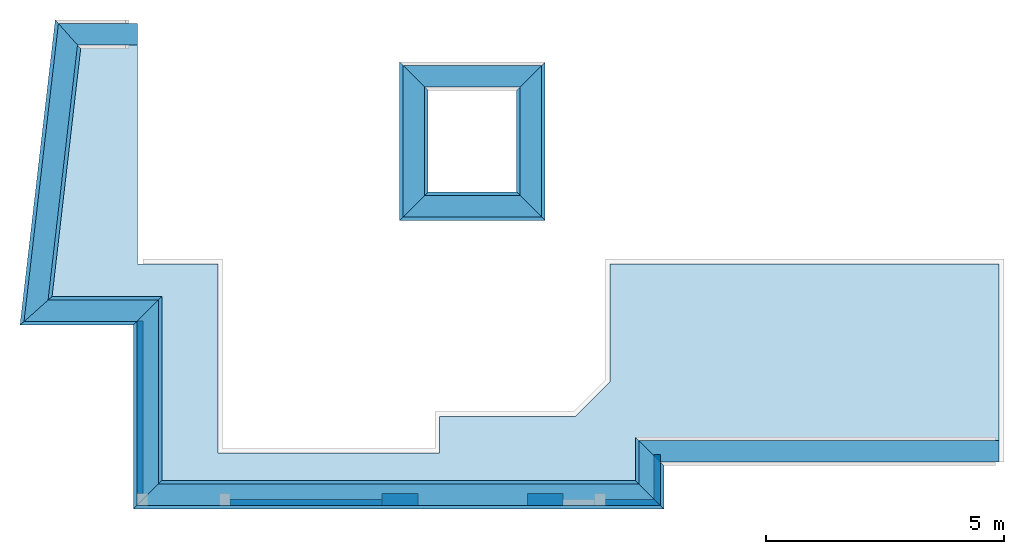
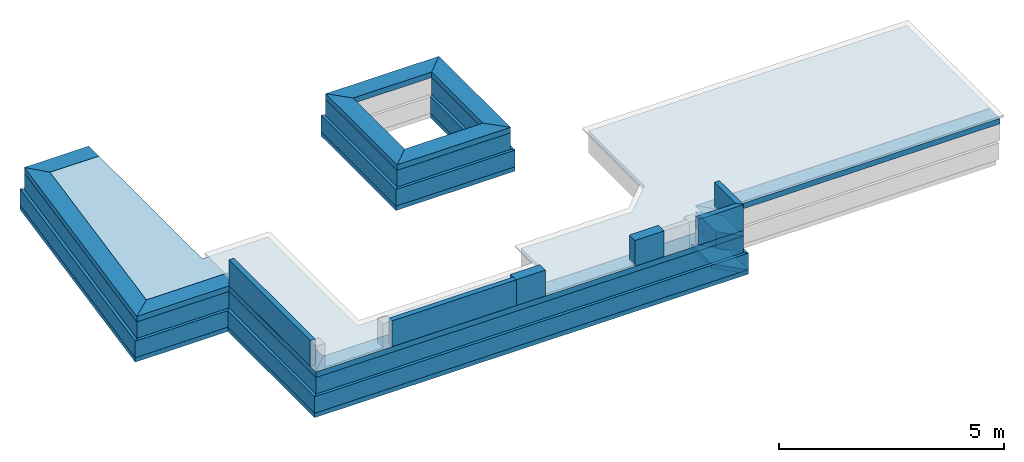
# One storey, part 1 of 4: 30 walls, 11 beams, 1 slab.
"""IFC4X3_ADD2 building model written with IfcOpenShell, lengths in metres."""

from ifc_helpers import new_model, entity, si_unit, converted_unit, frame, origin_with_axes, origin_2d_with_axis, place, context, subcontext, project, spatial, line, indexed_curve, outline, extrude, material, layer, layer_set, layer_usage, type_object, element, save


model = new_model("IFC4X3_ADD2")

# Units and contexts
model_context = context("Model", 3, precision=1e-05, world=origin_with_axes())
plan_context = context("Plan", 2, precision=1e-05, world=origin_2d_with_axis())
body_context = subcontext(model_context, "Body", "Model", "MODEL_VIEW")
ifc_project = project(units=[si_unit("VOLUMEUNIT", "CUBIC_METRE"), si_unit("LENGTHUNIT", "METRE"), converted_unit("PLANEANGLEUNIT", "degree", entity("IfcReal", 0.0174532925199433), si_unit("PLANEANGLEUNIT", "RADIAN"), dimensions=[0, 0, 0, 0, 0, 0, 0]), si_unit("AREAUNIT", "SQUARE_METRE")], contexts=[model_context, plan_context])

# Site, building, storey
site_placement = place(None, origin_with_axes())
site = spatial("IfcSite", under=ifc_project, at=site_placement)
building_placement = place(site_placement, origin_with_axes())
building = spatial("IfcBuilding", under=site, at=building_placement, Name="Building")
storey_placement = place(building_placement, origin_with_axes())
storey = spatial("IfcBuildingStorey", under=building, at=storey_placement, Name="Verandah")

# Beams
ifc_material_1 = material(Name="brick2", Category="Materials")
ifc_layer_1 = layer(ifc_material_1, 0.00999999977648258)
ifc_material_2 = material(Name="Stone", Category="Structure")
ifc_layer_2 = layer(ifc_material_2, 0.430000007152557)
ifc_layer_3 = layer(ifc_material_1, 0.00999999977648258)
ifc_layer_set_1 = layer_set([ifc_layer_1, ifc_layer_2, ifc_layer_3], Name="concrete")
ifc_layer_usage_1 = layer_usage(ifc_layer_set_1, "AXIS2", "POSITIVE", 0.0)
beam_type = type_object("IfcBeamType", Name="450mm wide beam", PredefinedType="BEAM", material=ifc_layer_set_1)
beam_1_placement = place(storey_placement, frame((15.7540448127226, 11.6493429189982, 0.299999952316288), z_axis=(0.0, 0.0, 1.0), x_axis=(0.999999999999936, 3.57627868652321e-07, 0.0)))
element("IfcBeam", 1, at=beam_1_placement, inside=storey, type_object=beam_type, material=ifc_layer_usage_1, Name="Beam", context=body_context, shape_type="SweptSolid", body=[
    extrude(outline(indexed_curve([(0.450000006705523, 0.0), (1.96701282195799e-08, 0.450000006705522), (7.57097232813434, 0.450000006705522), (7.57097230983239, 0.0)], segments=[line(1, 2, 3, 4, 1)])), origin_with_axes(), (0.0, 0.0, 1.0), 0.150000005960464),
])
ifc_layer_usage_2 = layer_usage(ifc_layer_set_1, "AXIS2", "POSITIVE", 0.0)
beam_2_placement = place(storey_placement, frame((15.7540448127226, 11.6493429189982, 0.299999952316288), z_axis=(0.0, 0.0, 1.0), x_axis=(3.13916473260163e-07, -0.999999999999951, 0.0)))
element("IfcBeam", 2, at=beam_2_placement, inside=storey, type_object=beam_type, material=ifc_layer_usage_2, Name="Beam", context=body_context, shape_type="SweptSolid", body=[
    extrude(outline(indexed_curve([(-0.450000006705523, 0.0), (-2.04372883874935e-08, 0.450000006705522), (0.913205436559926, 0.450000006705522), (0.463205450491675, 0.0)], segments=[line(1, 2, 3, 4, 1)])), origin_with_axes(), (0.0, 0.0, 1.0), 0.150000005960464),
])
ifc_layer_usage_3 = layer_usage(ifc_layer_set_1, "AXIS2", "POSITIVE", 0.0)
beam_3_placement = place(storey_placement, frame((5.20271757983026, 10.7361336765302, 0.299999952316288), z_axis=(0.0, 0.0, 1.0), x_axis=(0.999999999999936, 3.57627868652321e-07, 0.0)))
element("IfcBeam", 3, at=beam_3_placement, inside=storey, type_object=beam_type, material=ifc_layer_usage_3, Name="Beam", context=body_context, shape_type="SweptSolid", body=[
    extrude(outline(indexed_curve([(0.0, 0.0), (0.45000002637565, 0.450000006705522), (10.5513275392333, 0.450000006705522), (11.0013275262687, 0.0)], segments=[line(1, 2, 3, 4, 1)])), origin_with_axes(), (0.0, 0.0, 1.0), 0.150000005960464),
])
ifc_layer_usage_4 = layer_usage(ifc_layer_set_1, "AXIS2", "POSITIVE", 0.0)
beam_4_placement = place(storey_placement, frame((5.20271636677999, 14.6003790231918, 0.299999952316288), z_axis=(0.0, 0.0, 1.0), x_axis=(3.13916473260163e-07, -0.999999999999951, 0.0)))
element("IfcBeam", 4, at=beam_4_placement, inside=storey, type_object=beam_type, material=ifc_layer_usage_4, Name="Beam", context=body_context, shape_type="SweptSolid", body=[
    extrude(outline(indexed_curve([(0.0, 0.0), (-0.450000028368439, 0.450000006705522), (3.41424531978198, 0.450000006705522), (3.86424534666183, 0.0)], segments=[line(1, 2, 3, 4, 1)])), origin_with_axes(), (0.0, 0.0, 1.0), 0.150000005960464),
])
ifc_layer_usage_5 = layer_usage(ifc_layer_set_1, "AXIS2", "POSITIVE", 0.0)
beam_5_placement = place(storey_placement, frame((3.28399853057781, 14.6003783249363, 0.299999952316288), z_axis=(0.0, 0.0, 1.0), x_axis=(0.999999999999936, 3.57627868652321e-07, 0.0)))
element("IfcBeam", 5, at=beam_5_placement, inside=storey, type_object=beam_type, material=ifc_layer_usage_5, Name="Beam", context=body_context, shape_type="SweptSolid", body=[
    extrude(outline(indexed_curve([(-0.452991198784577, 0.0), (0.0519713396144295, 0.450000006705522), (2.36871786257795, 0.450000006705522), (1.9187178362023, 0.0)], segments=[line(1, 2, 3, 4, 1)])), origin_with_axes(), (0.0, 0.0, 1.0), 0.150000005960464),
])
ifc_layer_usage_6 = layer_usage(ifc_layer_set_1, "AXIS2", "POSITIVE", 0.0)
beam_6_placement = place(storey_placement, frame((3.95536313564383, 20.4134866076835, 0.299999952316288), z_axis=(0.0, 0.0, 1.0), x_axis=(0.999999999999936, 3.57627868652321e-07, 0.0)))
element("IfcBeam", 6, at=beam_6_placement, inside=storey, type_object=beam_type, material=ifc_layer_usage_6, Name="Beam", context=body_context, shape_type="SweptSolid", body=[
    extrude(outline(indexed_curve([(0.0, 0.0), (-0.401019859170148, 0.450000006705522), (1.25867455409636, 0.450000006705522), (1.25867453325556, 0.0)], segments=[line(1, 2, 3, 4, 1)])), origin_with_axes(), (0.0, 0.0, 1.0), 0.150000005960464),
])
ifc_layer_usage_7 = layer_usage(ifc_layer_set_1, "AXIS2", "POSITIVE", 0.0)
beam_7_placement = place(storey_placement, frame((10.7956827422968, 19.5343851122715, 0.299999952316288), z_axis=(0.0, 0.0, 1.0), x_axis=(3.13916473260163e-07, -0.999999999999951, 0.0)))
element("IfcBeam", 7, at=beam_7_placement, inside=storey, type_object=beam_type, material=ifc_layer_usage_7, Name="Beam", context=body_context, shape_type="SweptSolid", body=[
    extrude(outline(indexed_curve([(-0.450000006705523, 0.0), (-1.96701281929279e-08, 0.450000006705522), (2.28836896166128, 0.450000006705522), (2.73836898803694, 0.0)], segments=[line(1, 2, 3, 4, 1)])), origin_with_axes(), (0.0, 0.0, 1.0), 0.150000005960464),
])
ifc_layer_usage_8 = layer_usage(ifc_layer_set_1, "AXIS2", "POSITIVE", 0.0)
beam_8_placement = place(storey_placement, frame((13.2589586517204, 19.5343859932076, 0.299999952316288), z_axis=(0.0, 0.0, 1.0), x_axis=(3.13916473260163e-07, -0.999999999999951, 0.0)))
element("IfcBeam", 8, at=beam_8_placement, inside=storey, type_object=beam_type, material=ifc_layer_usage_8, Name="Beam", context=body_context, shape_type="SweptSolid", body=[
    extrude(outline(indexed_curve([(0.0, 0.0), (-0.450000026375651, 0.450000006705522), (2.73836896836681, 0.450000006705522), (2.28836898133141, 0.0)], segments=[line(1, 2, 3, 4, 1)])), origin_with_axes(), (0.0, 0.0, 1.0), 0.150000005960464),
])
ifc_layer_usage_9 = layer_usage(ifc_layer_set_1, "AXIS2", "POSITIVE", 0.0)
beam_9_placement = place(storey_placement, frame((10.7956827422968, 19.5343851122715, 0.299999892711638), z_axis=(0.0, 0.0, 1.0), x_axis=(0.999999999999936, 3.57627868652321e-07, 0.0)))
element("IfcBeam", 9, at=beam_9_placement, inside=storey, type_object=beam_type, material=ifc_layer_usage_9, Name="Beam", context=body_context, shape_type="SweptSolid", body=[
    extrude(outline(indexed_curve([(0.450000006705523, 0.0), (1.96701282195799e-08, 0.450000006705522), (2.91327593579936, 0.450000006705522), (2.46327590942371, 0.0)], segments=[line(1, 2, 3, 4, 1)])), origin_with_axes(), (0.0, 0.0, 1.0), 0.150000005960464),
])
ifc_layer_usage_10 = layer_usage(ifc_layer_set_1, "AXIS2", "POSITIVE", 0.0)
beam_10_placement = place(storey_placement, frame((10.795683601916, 16.7960161242347, 0.299999892711638), z_axis=(0.0, 0.0, 1.0), x_axis=(0.999999999999936, 3.57627868652321e-07, 0.0)))
element("IfcBeam", 10, at=beam_10_placement, inside=storey, type_object=beam_type, material=ifc_layer_usage_10, Name="Beam", context=body_context, shape_type="SweptSolid", body=[
    extrude(outline(indexed_curve([(0.0, 0.0), (0.450000026375651, 0.450000006705522), (2.46327592909384, 0.450000006705522), (2.91327591612923, 0.0)], segments=[line(1, 2, 3, 4, 1)])), origin_with_axes(), (0.0, 0.0, 1.0), 0.150000005960464),
])
ifc_layer_usage_11 = layer_usage(ifc_layer_set_1, "AXIS2", "POSITIVE", 0.0)
beam_11_placement = place(storey_placement, frame((3.28399853098188, 14.600378328435, 0.299999952316288), z_axis=(0.0, 0.0, 1.0), x_axis=(0.114728892793783, 0.99339683971629, 0.0)))
element("IfcBeam", 11, at=beam_11_placement, inside=storey, type_object=beam_type, material=ifc_layer_usage_11, Name="Beam", context=body_context, shape_type="SweptSolid", body=[
    extrude(outline(indexed_curve([(0.452991199106924, 0.0), (-0.0519713424240595, 0.450000006705522), (6.25276817398, 0.450000006705522), (5.85174831480985, 0.0)], segments=[line(1, 2, 3, 4, 1)])), origin_with_axes(), (0.0, 0.0, 1.0), 0.150000005960464),
])

# Slab
ifc_material_3 = material(Name="Concrete")
ifc_layer_4 = layer(ifc_material_3, 0.100000001490116)
ifc_layer_set_2 = layer_set([ifc_layer_4])
ifc_layer_usage_12 = layer_usage(ifc_layer_set_2, "AXIS3", "POSITIVE", -0.100000001490116)
slab_type = type_object("IfcSlabType", Name="PCC 10cm", PredefinedType="FLOOR", material=ifc_layer_set_2)
slab_placement = place(storey_placement, frame((16.1664161682129, 18.8340358734131, 0.449999988079071), z_axis=(0.0, 0.0, 1.0), x_axis=(1.0, 0.0, 0.0)))
element("IfcSlab", 12, at=slab_placement, inside=storey, type_object=slab_type, material=ifc_layer_usage_12, Name="Slab", context=body_context, shape_type="SweptSolid", body=[
    extrude(outline(indexed_curve([(-1.01973915100098, -5.49912452697754), (-1.01967811584473, -3.01801776885986), (7.15860080718994, -3.01801776885986), (7.15860080718994, -6.73469066619873), (-0.412372142076492, -6.73469066619873), (-0.412372142076492, -7.64789867401123), (-1.01973915100098, -7.64789867401123), (-4.60341644287109, -7.64789867401123), (-10.5136985778809, -7.64789867401123), (-10.5136985778809, -6.923011302948), (-10.5136985778809, -3.78365659713745), (-10.9523773193359, -3.78365659713745), (-12.8304462432861, -3.78365755081177), (-12.7469787597656, -3.06095457077026), (-12.2199640274048, 1.5894513130188), (-10.9523773193359, 1.57944917678833), (-10.9523773193359, -3.01801633834839), (-10.5136985778809, -3.01801633834839), (-9.26281929016113, -3.01801633834839), (-9.26281929016113, -3.78365659713745), (-9.26281929016113, -6.99801397323608), (-4.60341644287109, -6.99801397323608), (-4.60341644287109, -6.22681427001953), (-1.74742984771729, -6.22681331634521), (-1.01973915100098, -5.49912452697754)])), frame((0.0, 0.0, -0.100000001490116), z_axis=(0.0, 0.0, 1.0), x_axis=(1.0, 0.0, 0.0)), (0.0, 0.0, 1.0), 0.100000001490116),
])

# Walls
ifc_layer_5 = layer(ifc_material_2, 0.449999988079071)
ifc_layer_set_3 = layer_set([ifc_layer_5])
ifc_layer_usage_13 = layer_usage(ifc_layer_set_3, "AXIS2", "POSITIVE", 0.0)
wall_type_1 = type_object("IfcWallType", Name="RRB_0.45W", PredefinedType="SHEAR", material=ifc_layer_set_3)
wall_1_placement = place(storey_placement, frame((5.65271663666227, 10.7361380519159, -0.150000005960464), z_axis=(0.0, 0.0, 1.0), x_axis=(0.999999999999822, -5.960464477538e-07, 0.0)))
element("IfcWall", 13, at=wall_1_placement, inside=storey, type_object=wall_type_1, material=ifc_layer_usage_13, Name="Wall", context=body_context, shape_type="SweptSolid", body=[
    extrude(outline(indexed_curve([(-0.449999988079075, 0.0), (5.25674046514268e-08, 0.449999988079071), (10.1013277162238, 0.449999988079071), (10.5513277053796, 0.0)], segments=[line(1, 2, 3, 4, 1)])), origin_with_axes(), (0.0, 0.0, 1.0), 0.449999988079071),
])
ifc_layer_usage_14 = layer_usage(ifc_layer_set_3, "AXIS2", "POSITIVE", 0.0)
wall_2_placement = place(storey_placement, frame((16.20404434204, 10.736131697641, -0.150000005960464), z_axis=(0.0, 0.0, 1.0), x_axis=(5.52335052361657e-07, 0.999999999999847, 0.0)))
element("IfcWall", 14, at=wall_2_placement, inside=storey, type_object=wall_type_1, material=ifc_layer_usage_14, Name="Wall", context=body_context, shape_type="SweptSolid", body=[
    extrude(outline(indexed_curve([(0.0, 0.0), (0.450000014070418, 0.449999988079071), (1.36321715701571, 0.449999988079071), (0.913217137078231, 0.0)], segments=[line(1, 2, 3, 4, 1)])), origin_with_axes(), (0.0, 0.0, 1.0), 0.449999988079071),
])
ifc_layer_usage_15 = layer_usage(ifc_layer_set_3, "AXIS2", "POSITIVE", 0.0)
wall_3_placement = place(storey_placement, frame((5.652716636662, 10.7361380519159, -0.150000005960464), z_axis=(0.0, 0.0, 1.0), x_axis=(6.71544341912371e-07, 0.999999999999775, 0.0)))
element("IfcWall", 15, at=wall_3_placement, inside=storey, type_object=wall_type_1, material=ifc_layer_usage_15, Name="Wall", context=body_context, shape_type="SweptSolid", body=[
    extrude(outline(indexed_curve([(0.449999988079072, 0.0), (-3.11936364927887e-08, 0.449999988079071), (3.86423789734284, 0.449999988079071), (4.31423788649869, 0.0)], segments=[line(1, 2, 3, 4, 1)])), origin_with_axes(), (0.0, 0.0, 1.0), 0.449999988079071),
])
ifc_layer_usage_16 = layer_usage(ifc_layer_set_3, "AXIS2", "POSITIVE", 0.0)
wall_4_placement = place(storey_placement, frame((5.65271957159687, 15.0503759384137, -0.150000005960464), z_axis=(0.0, 0.0, 1.0), x_axis=(-0.999999999999803, 6.27832946520233e-07, 0.0)))
element("IfcWall", 16, at=wall_4_placement, inside=storey, type_object=wall_type_1, material=ifc_layer_usage_16, Name="Wall", context=body_context, shape_type="SweptSolid", body=[
    extrude(outline(indexed_curve([(0.0, 0.0), (0.450000011684951, 0.449999988079071), (2.82171083416142, 0.449999988079071), (2.31674855085093, 0.0)], segments=[line(1, 2, 3, 4, 1)])), origin_with_axes(), (0.0, 0.0, 1.0), 0.449999988079071),
])
ifc_layer_usage_17 = layer_usage(ifc_layer_set_3, "AXIS2", "POSITIVE", 0.0)
wall_5_placement = place(storey_placement, frame((11.2456821454564, 17.2460187833052, -0.150000005960464), z_axis=(0.0, 0.0, 1.0), x_axis=(6.71544341912371e-07, 0.999999999999775, 0.0)))
element("IfcWall", 17, at=wall_5_placement, inside=storey, type_object=wall_type_1, material=ifc_layer_usage_17, Name="Wall", context=body_context, shape_type="SweptSolid", body=[
    extrude(outline(indexed_curve([(0.0, 0.0), (-0.449999999482186, 0.449999988079071), (2.73836903409186, 0.449999988079071), (2.28836904708957, 0.0)], segments=[line(1, 2, 3, 4, 1)])), origin_with_axes(), (0.0, 0.0, 1.0), 0.449999988079071),
])
ifc_layer_usage_18 = layer_usage(ifc_layer_set_3, "AXIS2", "POSITIVE", 0.0)
wall_6_placement = place(storey_placement, frame((13.7089580548791, 17.2460171915262, -0.150000005960464), z_axis=(0.0, 0.0, 1.0), x_axis=(6.71544341912371e-07, 0.999999999999775, 0.0)))
element("IfcWall", 18, at=wall_6_placement, inside=storey, type_object=wall_type_1, material=ifc_layer_usage_18, Name="Wall", context=body_context, shape_type="SweptSolid", body=[
    extrude(outline(indexed_curve([(-0.449999988079071, 0.0), (-1.14031152298466e-08, 0.449999988079071), (2.2883689947009, 0.449999988079071), (2.73836899555693, 0.0)], segments=[line(1, 2, 3, 4, 1)])), origin_with_axes(), (0.0, 0.0, 1.0), 0.449999988079071),
])
ifc_layer_usage_19 = layer_usage(ifc_layer_set_3, "AXIS2", "POSITIVE", 0.0)
wall_7_placement = place(storey_placement, frame((13.7089580548791, 17.2460171990466, -0.150000020861626), z_axis=(0.0, 0.0, 1.0), x_axis=(-0.999999999999803, 6.27832946520233e-07, 0.0)))
element("IfcWall", 19, at=wall_7_placement, inside=storey, type_object=wall_type_1, material=ifc_layer_usage_19, Name="Wall", context=body_context, shape_type="SweptSolid", body=[
    extrude(outline(indexed_curve([(0.449999988079072, 0.0), (2.58708144351694e-08, 0.449999988079071), (2.91327592337316, 0.449999988079071), (2.46327590942327, 0.0)], segments=[line(1, 2, 3, 4, 1)])), origin_with_axes(), (0.0, 0.0, 1.0), 0.449999988079071),
])
ifc_layer_usage_20 = layer_usage(ifc_layer_set_3, "AXIS2", "POSITIVE", 0.0)
wall_8_placement = place(storey_placement, frame((3.55434743009632, 20.8634848330948, -0.150000005960464), z_axis=(0.0, 0.0, 1.0), x_axis=(-0.114729399557727, -0.99339678118923, 0.0)))
element("IfcWall", 20, at=wall_8_placement, inside=storey, type_object=wall_type_1, material=ifc_layer_usage_20, Name="Wall", context=body_context, shape_type="SweptSolid", body=[
    extrude(outline(indexed_curve([(0.0, 0.0), (0.401020051245883, 0.449999988079071), (5.79977630955525, 0.449999988079071), (6.30473856476878, 0.0)], segments=[line(1, 2, 3, 4, 1)])), origin_with_axes(), (0.0, 0.0, 1.0), 0.449999988079071),
])
ifc_material_4 = material(Name="Wall")
ifc_layer_6 = layer(ifc_material_4, 0.600000023841858, Name="concrete")
ifc_layer_set_4 = layer_set([ifc_layer_6], Name="concrete")
ifc_layer_usage_21 = layer_usage(ifc_layer_set_4, "AXIS2", "POSITIVE", 0.0)
wall_type_2 = type_object("IfcWallType", Name="RRB_0.6W", PredefinedType="SHEAR", material=ifc_layer_set_4)
wall_9_placement = place(storey_placement, frame((15.6790454136462, 11.2611335276763, -0.600000023841858), z_axis=(0.0, 0.0, 1.0), x_axis=(-0.999999999999924, 3.89414367418765e-07, 0.0)))
element("IfcWall", 21, at=wall_9_placement, inside=storey, type_object=wall_type_2, material=ifc_layer_usage_21, Name="Wall", context=body_context, shape_type="SweptSolid", body=[
    extrude(outline(indexed_curve([(0.0, 0.0), (-0.599998054716328, 0.600000023841858), (10.5513305503478, 0.600000023841858), (9.95133056357225, 0.0)], segments=[line(1, 2, 3, 4, 1)])), origin_with_axes(), (0.0, 0.0, 1.0), 0.449999988079071),
])
ifc_layer_usage_22 = layer_usage(ifc_layer_set_4, "AXIS2", "POSITIVE", 0.0)
wall_10_placement = place(storey_placement, frame((15.6790487663207, 12.174347695086, -0.600000023841858), z_axis=(0.0, 0.0, 1.0), x_axis=(-5.2054855359522e-07, -0.999999999999865, 0.0)))
element("IfcWall", 22, at=wall_10_placement, inside=storey, type_object=wall_type_2, material=ifc_layer_usage_22, Name="Wall", context=body_context, shape_type="SweptSolid", body=[
    extrude(outline(indexed_curve([(0.0, 0.0), (0.599999939609788, 0.600000023841858), (1.51321410886504, 0.600000023841858), (0.913214167410906, 0.0)], segments=[line(1, 2, 3, 4, 1)])), origin_with_axes(), (0.0, 0.0, 1.0), 0.449999988079071),
])
ifc_layer_usage_23 = layer_usage(ifc_layer_set_4, "AXIS2", "POSITIVE", 0.0)
wall_11_placement = place(storey_placement, frame((5.1277161086956, 15.1253715398588, -0.600000023841858), z_axis=(0.0, 0.0, 1.0), x_axis=(-5.2054855359522e-07, -0.999999999999865, 0.0)))
element("IfcWall", 23, at=wall_11_placement, inside=storey, type_object=wall_type_2, material=ifc_layer_usage_23, Name="Wall", context=body_context, shape_type="SweptSolid", body=[
    extrude(outline(indexed_curve([(0.600000023841861, 0.0), (5.95834321742705e-08, 0.600000023841858), (3.86423388614875, 0.600000023841858), (4.46423399237835, 0.0)], segments=[line(1, 2, 3, 4, 1)])), origin_with_axes(), (0.0, 0.0, 1.0), 0.449999988079071),
])
ifc_layer_usage_24 = layer_usage(ifc_layer_set_4, "AXIS2", "POSITIVE", 0.0)
wall_12_placement = place(storey_placement, frame((5.1277161086956, 15.1253715470741, -0.600000023841858), z_axis=(0.0, 0.0, 1.0), x_axis=(-0.999999999999803, 6.27832946520233e-07, 0.0)))
element("IfcWall", 24, at=wall_12_placement, inside=storey, type_object=wall_type_2, material=ifc_layer_usage_24, Name="Wall", context=body_context, shape_type="SweptSolid", body=[
    extrude(outline(indexed_curve([(-0.600000023841874, 0.0), (-1.77571658523227e-07, 0.600000023841858), (2.38086932746782, 0.600000023841858), (1.7075862513005, 0.0)], segments=[line(1, 2, 3, 4, 1)])), origin_with_axes(), (0.0, 0.0, 1.0), 0.449999988079071),
])
ifc_layer_usage_25 = layer_usage(ifc_layer_set_4, "AXIS2", "POSITIVE", 0.0)
wall_13_placement = place(storey_placement, frame((10.7206868734992, 19.4593928708772, -0.600000023841858), z_axis=(0.0, 0.0, 1.0), x_axis=(-5.2054855359522e-07, -0.999999999999865, 0.0)))
element("IfcWall", 25, at=wall_13_placement, inside=storey, type_object=wall_type_2, material=ifc_layer_usage_25, Name="Wall", context=body_context, shape_type="SweptSolid", body=[
    extrude(outline(indexed_curve([(-0.600000023841776, 0.0), (1.86421843027806e-06, 0.600000023841858), (2.13837337255072, 0.600000023841858), (2.73837258208978, 0.0)], segments=[line(1, 2, 3, 4, 1)])), origin_with_axes(), (0.0, 0.0, 1.0), 0.449999988079071),
])
ifc_layer_usage_26 = layer_usage(ifc_layer_set_4, "AXIS2", "POSITIVE", 0.0)
wall_14_placement = place(storey_placement, frame((13.1839627829191, 19.459385224953, -0.600000023841858), z_axis=(0.0, 0.0, 1.0), x_axis=(-5.2054855359522e-07, -0.999999999999865, 0.0)))
element("IfcWall", 26, at=wall_14_placement, inside=storey, type_object=wall_type_2, material=ifc_layer_usage_26, Name="Wall", context=body_context, shape_type="SweptSolid", body=[
    extrude(outline(indexed_curve([(0.0, 0.0), (-0.599999349220907, 0.600000023841858), (2.73837037581012, 0.600000023841858), (2.13836953766554, 0.0)], segments=[line(1, 2, 3, 4, 1)])), origin_with_axes(), (0.0, 0.0, 1.0), 0.449999988079071),
])
ifc_layer_usage_27 = layer_usage(ifc_layer_set_4, "AXIS2", "POSITIVE", 0.0)
wall_15_placement = place(storey_placement, frame((10.7206825707411, 16.7210202888016, -0.600000023841858), z_axis=(0.0, 0.0, 1.0), x_axis=(0.999999999999886, -4.76837158203071e-07, 0.0)))
element("IfcWall", 27, at=wall_15_placement, inside=storey, type_object=wall_type_2, material=ifc_layer_usage_27, Name="Wall", context=body_context, shape_type="SweptSolid", body=[
    extrude(outline(indexed_curve([(0.0, 0.0), (0.600000680509379, 0.600000023841858), (2.46327656609531, 0.600000023841858), (3.06327593326901, 0.0)], segments=[line(1, 2, 3, 4, 1)])), origin_with_axes(), (0.0, 0.0, 1.0), 0.449999988079071),
])
ifc_layer_usage_28 = layer_usage(ifc_layer_set_4, "AXIS2", "POSITIVE", 0.0)
wall_16_placement = place(storey_placement, frame((3.48750964878186, 20.9384852020161, -0.600000023841858), z_axis=(0.0, 0.0, 1.0), x_axis=(-0.114729399557727, -0.99339678118923, 0.0)))
element("IfcWall", 28, at=wall_16_placement, inside=storey, type_object=wall_type_2, material=ifc_layer_usage_28, Name="Wall", context=body_context, shape_type="SweptSolid", body=[
    extrude(outline(indexed_curve([(0.0, 0.0), (0.534693409766792, 0.600000023841858), (5.78245779276086, 0.600000023841858), (6.45574087911888, 0.0)], segments=[line(1, 2, 3, 4, 1)])), origin_with_axes(), (0.0, 0.0, 1.0), 0.449999988079071),
])
ifc_layer_7 = layer(ifc_material_4, 0.600000023841858, Name="concrete")
ifc_layer_set_5 = layer_set([ifc_layer_7])
ifc_layer_usage_29 = layer_usage(ifc_layer_set_5, "AXIS2", "POSITIVE", 0.0)
wall_type_3 = type_object("IfcWallType", PredefinedType="SHEAR", material=ifc_layer_set_5)
wall_17_placement = place(storey_placement, frame((15.6790446116332, 11.2611338197374, -0.720000028610229), z_axis=(0.0, 0.0, 1.0), x_axis=(-0.999999999999924, 3.89414367418765e-07, 0.0)))
element("IfcWall", 29, at=wall_17_placement, inside=storey, type_object=wall_type_3, material=ifc_layer_usage_29, Name="Wall", context=body_context, shape_type="SweptSolid", body=[
    extrude(outline(indexed_curve([(0.0, 0.0), (-0.599999967920739, 0.600000023841858), (10.5513305175964, 0.600000023841858), (9.95133042542427, 0.0)], segments=[line(1, 2, 3, 4, 1)])), origin_with_axes(), (0.0, 0.0, 1.0), 0.119999997317791),
])
ifc_layer_usage_30 = layer_usage(ifc_layer_set_5, "AXIS2", "POSITIVE", 0.0)
wall_18_placement = place(storey_placement, frame((5.12771610869562, 15.1253715864194, -0.720000028610229), z_axis=(0.0, 0.0, 1.0), x_axis=(-5.2054855359522e-07, -0.999999999999865, 0.0)))
element("IfcWall", 30, at=wall_18_placement, inside=storey, type_object=wall_type_3, material=ifc_layer_usage_30, Name="Wall", context=body_context, shape_type="SweptSolid", body=[
    extrude(outline(indexed_curve([(0.600000023841861, 0.0), (5.96269755653855e-08, 0.600000023841858), (3.86423364064859, 0.600000023841858), (4.46423374687819, 0.0)], segments=[line(1, 2, 3, 4, 1)])), origin_with_axes(), (0.0, 0.0, 1.0), 0.119999997317791),
])
ifc_layer_usage_31 = layer_usage(ifc_layer_set_5, "AXIS2", "POSITIVE", 0.0)
wall_19_placement = place(storey_placement, frame((15.6790451172703, 12.1743476366754, -0.720000028610229), z_axis=(0.0, 0.0, 1.0), x_axis=(-6.39757843145941e-07, -0.999999999999795, 0.0)))
element("IfcWall", 31, at=wall_19_placement, inside=storey, type_object=wall_type_3, material=ifc_layer_usage_31, Name="Wall", context=body_context, shape_type="SweptSolid", body=[
    extrude(outline(indexed_curve([(0.0, 0.0), (0.599999868892124, 0.600000023841858), (1.51321368686675, 0.600000023841858), (0.913213816938183, 0.0)], segments=[line(1, 2, 3, 4, 1)])), origin_with_axes(), (0.0, 0.0, 1.0), 0.119999997317791),
])
ifc_layer_usage_32 = layer_usage(ifc_layer_set_5, "AXIS2", "POSITIVE", 0.0)
wall_20_placement = place(storey_placement, frame((5.12771610869562, 15.125371594162, -0.720000028610229), z_axis=(0.0, 0.0, 1.0), x_axis=(-0.999999999999803, 6.27832946520233e-07, 0.0)))
element("IfcWall", 32, at=wall_20_placement, inside=storey, type_object=wall_type_3, material=ifc_layer_usage_32, Name="Wall", context=body_context, shape_type="SweptSolid", body=[
    extrude(outline(indexed_curve([(-0.600000023841863, 0.0), (-7.44932391151584e-08, 0.600000023841858), (2.38086927250564, 0.600000023841858), (1.70758619634341, 0.0)], segments=[line(1, 2, 3, 4, 1)])), origin_with_axes(), (0.0, 0.0, 1.0), 0.119999997317791),
])
ifc_layer_usage_33 = layer_usage(ifc_layer_set_5, "AXIS2", "POSITIVE", 0.0)
wall_21_placement = place(storey_placement, frame((10.7206830498573, 19.4593854078441, -0.720000028610229), z_axis=(0.0, 0.0, 1.0), x_axis=(-6.39757843145941e-07, -0.999999999999795, 0.0)))
element("IfcWall", 33, at=wall_21_placement, inside=storey, type_object=wall_type_3, material=ifc_layer_usage_33, Name="Wall", context=body_context, shape_type="SweptSolid", body=[
    extrude(outline(indexed_curve([(-0.600000023841863, 0.0), (-1.26312289003283e-07, 0.600000023841858), (2.13836870318869, 0.600000023841858), (2.73836879775748, 0.0)], segments=[line(1, 2, 3, 4, 1)])), origin_with_axes(), (0.0, 0.0, 1.0), 0.119999997317791),
])
ifc_layer_usage_34 = layer_usage(ifc_layer_set_5, "AXIS2", "POSITIVE", 0.0)
wall_22_placement = place(storey_placement, frame((13.1839589592805, 19.4593842822288, -0.720000028610229), z_axis=(0.0, 0.0, 1.0), x_axis=(-6.39757843145941e-07, -0.999999999999795, 0.0)))
element("IfcWall", 34, at=wall_22_placement, inside=storey, type_object=wall_type_3, material=ifc_layer_usage_34, Name="Wall", context=body_context, shape_type="SweptSolid", body=[
    extrude(outline(indexed_curve([(0.0, 0.0), (-0.600000087173521, 0.600000023841858), (2.738368924705, 0.600000023841858), (2.1383689641948, 0.0)], segments=[line(1, 2, 3, 4, 1)])), origin_with_axes(), (0.0, 0.0, 1.0), 0.119999997317791),
])
ifc_layer_usage_35 = layer_usage(ifc_layer_set_5, "AXIS2", "POSITIVE", 0.0)
wall_23_placement = place(storey_placement, frame((10.7206814502968, 16.7210166100871, -0.720000028610229), z_axis=(0.0, 0.0, 1.0), x_axis=(0.999999999999822, -5.960464477538e-07, 0.0)))
element("IfcWall", 35, at=wall_23_placement, inside=storey, type_object=wall_type_3, material=ifc_layer_usage_35, Name="Wall", context=body_context, shape_type="SweptSolid", body=[
    extrude(outline(indexed_curve([(0.0, 0.0), (0.600000016691374, 0.600000023841858), (2.46327617193386, 0.600000023841858), (3.06327627858975, 0.0)], segments=[line(1, 2, 3, 4, 1)])), origin_with_axes(), (0.0, 0.0, 1.0), 0.119999997317791),
])
ifc_layer_usage_36 = layer_usage(ifc_layer_set_5, "AXIS2", "POSITIVE", 0.0)
wall_24_placement = place(storey_placement, frame((3.48750969788129, 20.9384852015846, -0.720000028610229), z_axis=(0.0, 0.0, 1.0), x_axis=(-0.114729399557727, -0.99339678118923, 0.0)))
element("IfcWall", 36, at=wall_24_placement, inside=storey, type_object=wall_type_3, material=ifc_layer_usage_36, Name="Wall", context=body_context, shape_type="SweptSolid", body=[
    extrude(outline(indexed_curve([(0.0, 0.0), (0.534693409828114, 0.600000023841858), (5.78245774519899, 0.600000023841858), (6.4557408316648, 0.0)], segments=[line(1, 2, 3, 4, 1)])), origin_with_axes(), (0.0, 0.0, 1.0), 0.119999997317791),
])
ifc_material_5 = material(Name="Plaster", Category="Finishes")
ifc_layer_8 = layer(ifc_material_5, 0.0149999996647239, Name="plaster")
ifc_material_6 = material(Name="Brick")
ifc_layer_9 = layer(ifc_material_6, 0.100000001490116, Name="brick")
ifc_layer_10 = layer(ifc_material_5, 0.0149999996647239, Name="plaster")
ifc_layer_set_6 = layer_set([ifc_layer_8, ifc_layer_9, ifc_layer_10], Name="brick2")
ifc_layer_usage_37 = layer_usage(ifc_layer_set_6, "AXIS2", "POSITIVE", 0.0)
wall_type_4 = type_object("IfcWallType", Name="Wall 130mm", PredefinedType="SOLIDWALL", material=ifc_layer_set_6)
wall_25_placement = place(storey_placement, frame((7.16404151916504, 10.7361326217651, 0.453000009059906), z_axis=(0.0, 0.0, 1.0), x_axis=(1.0, 0.0, 0.0)))
element("IfcWall", 37, at=wall_25_placement, inside=storey, type_object=wall_type_4, material=ifc_layer_usage_37, Name="Wall", context=body_context, shape_type="SweptSolid", body=[
    extrude(outline(indexed_curve([(0.0, 0.0), (0.0, 0.130000000819564), (3.19429683685303, 0.130000000819564), (3.19429683685303, 0.0)], segments=[line(1, 2, 3, 4, 1)])), origin_with_axes(), (0.0, 0.0, 1.0), 0.699999988079071),
])
ifc_layer_usage_38 = layer_usage(ifc_layer_set_6, "AXIS2", "POSITIVE", 0.0)
wall_26_placement = place(storey_placement, frame((5.20379035688426, 14.6120086092584, 0.453000009059906), z_axis=(0.0, 0.0, 1.0), x_axis=(-2.82129974493717e-07, -0.99999999999996, 0.0)))
element("IfcWall", 38, at=wall_26_placement, inside=storey, type_object=wall_type_4, material=ifc_layer_usage_38, Name="Wall", context=body_context, shape_type="SweptSolid", body=[
    extrude(outline(indexed_curve([(0.0, 0.0), (0.0, 0.130000000819564), (3.62587603956778, 0.130000000819564), (3.62587607624474, 0.0)], segments=[line(1, 2, 3, 4, 1)])), origin_with_axes(), (0.0, 0.0, 1.0), 0.699999988079071),
])
ifc_layer_usage_39 = layer_usage(ifc_layer_set_6, "AXIS2", "POSITIVE", 0.0)
wall_27_placement = place(storey_placement, frame((15.0466747283936, 10.7361326217651, 0.453000009059906), z_axis=(0.0, 0.0, 1.0), x_axis=(1.0, 0.0, 0.0)))
element("IfcWall", 39, at=wall_27_placement, inside=storey, type_object=wall_type_4, material=ifc_layer_usage_39, Name="Wall", context=body_context, shape_type="SweptSolid", body=[
    extrude(outline(indexed_curve([(0.0, 0.0), (0.0, 0.130000000819564), (1.02737005727631, 0.130000000819564), (1.15737005809586, 0.0)], segments=[line(1, 2, 3, 4, 1)])), origin_with_axes(), (0.0, 0.0, 1.0), 0.699999988079071),
])
ifc_layer_usage_40 = layer_usage(ifc_layer_set_6, "AXIS2", "POSITIVE", 0.0)
wall_28_placement = place(storey_placement, frame((16.2040447864895, 10.7361326217651, 0.453000009059906), z_axis=(0.0, 0.0, 1.0), x_axis=(3.13916473260163e-07, 0.999999999999951, 0.0)))
element("IfcWall", 40, at=wall_28_placement, inside=storey, type_object=wall_type_4, material=ifc_layer_usage_40, Name="Wall", context=body_context, shape_type="SweptSolid", body=[
    extrude(outline(indexed_curve([(0.0, 0.0), (0.129999960010428, 0.130000000819564), (1.0720199346541, 0.130000000819564), (1.0720199346541, 0.0)], segments=[line(1, 2, 3, 4, 1)])), origin_with_axes(), (0.0, 0.0, 1.0), 0.699999988079071),
])
ifc_layer_11 = layer(ifc_material_5, 0.00999999977648258, Name="plaster")
ifc_material_7 = material(Name="Brick")
ifc_layer_12 = layer(ifc_material_7, 0.230000004172325, Name="brick")
ifc_layer_13 = layer(ifc_material_5, 0.00999999977648258, Name="plaster")
ifc_layer_set_7 = layer_set([ifc_layer_11, ifc_layer_12, ifc_layer_13], Name="brick")
ifc_layer_usage_41 = layer_usage(ifc_layer_set_7, "AXIS2", "POSITIVE", 0.0)
wall_type_5 = type_object("IfcWallType", Name="Wall 250mm export", PredefinedType="SOLIDWALL", material=ifc_layer_set_7)
wall_29_placement = place(storey_placement, frame((10.3583383063325, 10.7361327731651, 0.453000009059906), z_axis=(0.0, 0.0, 1.0), x_axis=(0.999999999999744, -7.15255737304505e-07, 0.0)))
element("IfcWall", 41, at=wall_29_placement, inside=storey, type_object=wall_type_5, material=ifc_layer_usage_41, Name="Wall", context=body_context, shape_type="SweptSolid", body=[
    extrude(outline(indexed_curve([(0.0, 0.0), (0.0, 0.25000000372529), (0.749999990081051, 0.25000000372529), (0.749999990081051, 0.0)], segments=[line(1, 2, 3, 4, 1)])), origin_with_axes(), (0.0, 0.0, 1.0), 0.699999988079071),
])
ifc_layer_usage_42 = layer_usage(ifc_layer_set_7, "AXIS2", "POSITIVE", 0.0)
wall_30_placement = place(storey_placement, frame((13.4083384970673, 10.7361327731651, 0.453000009059906), z_axis=(0.0, 0.0, 1.0), x_axis=(0.999999999999744, -7.15255737304505e-07, 0.0)))
element("IfcWall", 42, at=wall_30_placement, inside=storey, type_object=wall_type_5, material=ifc_layer_usage_42, Name="Wall", context=body_context, shape_type="SweptSolid", body=[
    extrude(outline(indexed_curve([(0.0, 0.0), (0.0, 0.25000000372529), (0.749999990081051, 0.25000000372529), (0.749999990081051, 0.0)], segments=[line(1, 2, 3, 4, 1)])), origin_with_axes(), (0.0, 0.0, 1.0), 0.699999988079071),
])

save(model, "model.ifc")
